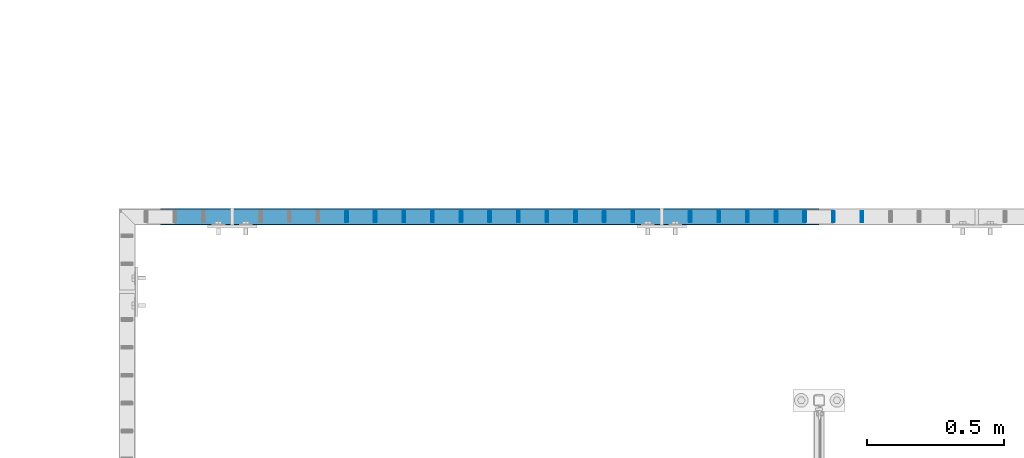
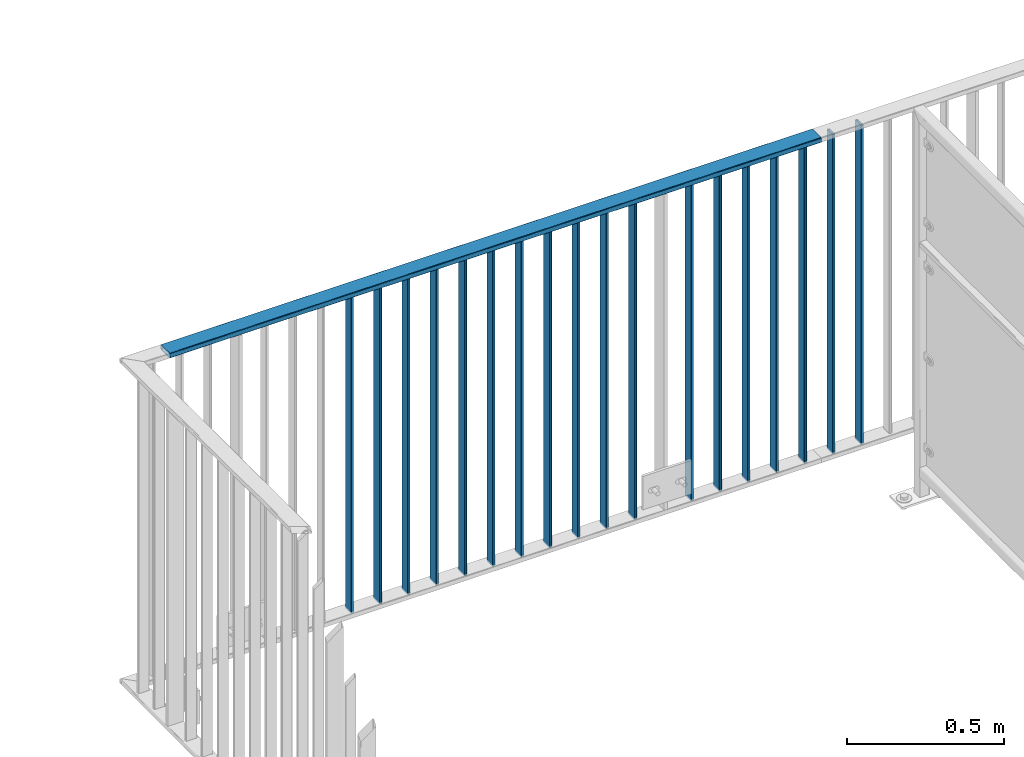
# One storey, part 27 of 156: 19 beams, 2 elements without a shape of their own.
"""IFC2X3 building model written with IfcOpenShell, lengths in millimetres."""

from ifc_helpers import new_model, si_unit, frame, origin_with_axes, origin_2d_with_axis, place, context, subcontext, project, spatial, hollow_rectangle, extrude, clip, halfspace, material, type_object, element, aggregate, save


model = new_model("IFC2X3")

# Units and contexts
model_context = context("Model", 3, precision=1e-05, world=origin_with_axes())
body_context = subcontext(model_context, "Body", "Model", "MODEL_VIEW")
ifc_project = project(units=[si_unit("LENGTHUNIT", "METRE", prefix="MILLI"), si_unit("AREAUNIT", "SQUARE_METRE"), si_unit("VOLUMEUNIT", "CUBIC_METRE"), si_unit("MASSUNIT", "GRAM", prefix="KILO"), si_unit("TIMEUNIT", "SECOND"), si_unit("PLANEANGLEUNIT", "RADIAN"), si_unit("SOLIDANGLEUNIT", "STERADIAN"), si_unit("THERMODYNAMICTEMPERATUREUNIT", "DEGREE_CELSIUS"), si_unit("LUMINOUSINTENSITYUNIT", "LUMEN")], contexts=[model_context])

# Site, building, storey
site_placement = place(None, origin_with_axes())
site = spatial("IfcSite", under=ifc_project, at=site_placement, CompositionType="ELEMENT")
building_placement = place(site_placement, origin_with_axes())
building = spatial("IfcBuilding", under=site, at=building_placement, Name="Undefined", CompositionType="ELEMENT")
storey_placement = place(building_placement, origin_with_axes())
storey = spatial("IfcBuildingStorey", under=building, at=storey_placement, Name="Undefined", CompositionType="ELEMENT", Elevation=0.0)

# Assembly, beams
assembly_1_placement = place(storey_placement, origin_with_axes())
assembly_1 = element("IfcElementAssembly", 1, at=assembly_1_placement, inside=storey, AssemblyPlace="NOTDEFINED", PredefinedType="RIGID_FRAME")
ifc_material = material(Name="STEEL/S235JR")
beam_type_1 = type_object("IfcBeamType", Name="K60/20/2", PredefinedType="NOTDEFINED")
beam_1_placement = place(assembly_1_placement, frame((33999.9535961914, 21657.9919947282, 3990.0), z_axis=(0.0, -1.0, 0.0), x_axis=(-1.0, 0.0, 0.0)))
beam_1 = element("IfcBeam", 2, at=beam_1_placement, type_object=beam_type_1, material=ifc_material, ObjectType="K60/20/2", context=body_context, shape_type="SweptSolid", body=[
    extrude(hollow_rectangle(XDim=20.0, YDim=60.0, WallThickness=2.0, InnerFilletRadius=2.0, OuterFilletRadius=4.0, at=origin_2d_with_axis()), frame((2402.81, 0.0, 0.0), z_axis=(-1.0, 0.0, 0.0), x_axis=(0.0, -1.0, 0.0)), (0.0, 0.0, 1.0), 2402.81),
])
beam_type_2 = type_object("IfcBeamType", Name="K40/10/1.5", PredefinedType="NOTDEFINED")
beam_2_placement = place(assembly_1_placement, frame((33320.8985961914, 21657.9919947282, 3980.00000000003), z_axis=(0.0, -1.0, 0.0), x_axis=(0.0, 0.0, -1.0)))
beam_2 = element("IfcBeam", 3, at=beam_2_placement, type_object=beam_type_2, material=ifc_material, ObjectType="K40/10/1.5", context=body_context, shape_type="Clipping", body=[
    clip(clip(extrude(hollow_rectangle(XDim=10.0, YDim=40.0, WallThickness=1.5, InnerFilletRadius=1.5, OuterFilletRadius=3.0, at=origin_2d_with_axis()), frame((1237.00000000003, 0.0, 0.0), z_axis=(-1.0, 0.0, 0.0), x_axis=(0.0, -1.0, 0.0)), (0.0, 0.0, 1.0), 1244.0), halfspace(frame((1237.00000000003, 4.34248751949781, 47.3810900558092), z_axis=(1.0, 0.0, 0.0), x_axis=(0.0, -0.768354814194188, -0.640024124158313)), False)), halfspace(frame((-6.99999999997453, -4.34248751950508, 47.3810900558092), z_axis=(-1.0, 0.0, 0.0), x_axis=(0.0, 0.7683548141934, -0.640024124159258)), False)),
])
beam_3_placement = place(assembly_1_placement, frame((32276.1985961914, 21657.9919947282, 3980.00000000003), z_axis=(0.0, -1.0, 0.0), x_axis=(0.0, 0.0, -1.0)))
beam_3 = element("IfcBeam", 4, at=beam_3_placement, type_object=beam_type_2, material=ifc_material, ObjectType="K40/10/1.5", context=body_context, shape_type="Clipping", body=[
    clip(clip(extrude(hollow_rectangle(XDim=10.0, YDim=40.0, WallThickness=1.5, InnerFilletRadius=1.5, OuterFilletRadius=3.0, at=origin_2d_with_axis()), frame((1237.00000000003, 0.0, 0.0), z_axis=(-1.0, 0.0, 0.0), x_axis=(0.0, -1.0, 0.0)), (0.0, 0.0, 1.0), 1244.0), halfspace(frame((1237.00000000003, 4.34248751949781, 47.3810900558092), z_axis=(1.0, 0.0, 0.0), x_axis=(0.0, -0.768354814194188, -0.640024124158313)), False)), halfspace(frame((-6.99999999997453, -4.34248751950508, 47.3810900558092), z_axis=(-1.0, 0.0, 0.0), x_axis=(0.0, 0.7683548141934, -0.640024124159258)), False)),
])
beam_4_placement = place(assembly_1_placement, frame((32380.6685961914, 21657.9919947282, 3980.00000000003), z_axis=(0.0, -1.0, 0.0), x_axis=(0.0, 0.0, -1.0)))
beam_4 = element("IfcBeam", 5, at=beam_4_placement, type_object=beam_type_2, material=ifc_material, ObjectType="K40/10/1.5", context=body_context, shape_type="Clipping", body=[
    clip(clip(extrude(hollow_rectangle(XDim=10.0, YDim=40.0, WallThickness=1.5, InnerFilletRadius=1.5, OuterFilletRadius=3.0, at=origin_2d_with_axis()), frame((1237.00000000003, 0.0, 0.0), z_axis=(-1.0, 0.0, 0.0), x_axis=(0.0, -1.0, 0.0)), (0.0, 0.0, 1.0), 1244.0), halfspace(frame((1237.00000000003, 4.34248751949781, 47.3810900558092), z_axis=(1.0, 0.0, 0.0), x_axis=(0.0, -0.768354814194188, -0.640024124158313)), False)), halfspace(frame((-6.99999999997453, -4.34248751950508, 47.3810900558092), z_axis=(-1.0, 0.0, 0.0), x_axis=(0.0, 0.7683548141934, -0.640024124159258)), False)),
])
beam_5_placement = place(assembly_1_placement, frame((32485.1385961914, 21657.9919947282, 3980.00000000003), z_axis=(0.0, -1.0, 0.0), x_axis=(0.0, 0.0, -1.0)))
beam_5 = element("IfcBeam", 6, at=beam_5_placement, type_object=beam_type_2, material=ifc_material, ObjectType="K40/10/1.5", context=body_context, shape_type="Clipping", body=[
    clip(clip(extrude(hollow_rectangle(XDim=10.0, YDim=40.0, WallThickness=1.5, InnerFilletRadius=1.5, OuterFilletRadius=3.0, at=origin_2d_with_axis()), frame((1237.00000000003, 0.0, 0.0), z_axis=(-1.0, 0.0, 0.0), x_axis=(0.0, -1.0, 0.0)), (0.0, 0.0, 1.0), 1244.0), halfspace(frame((1237.00000000003, 4.34248751949781, 47.3810900558092), z_axis=(1.0, 0.0, 0.0), x_axis=(0.0, -0.768354814194188, -0.640024124158313)), False)), halfspace(frame((-6.99999999997453, -4.34248751950508, 47.3810900558092), z_axis=(-1.0, 0.0, 0.0), x_axis=(0.0, 0.7683548141934, -0.640024124159258)), False)),
])
beam_6_placement = place(assembly_1_placement, frame((32589.6085961914, 21657.9919947282, 3980.00000000003), z_axis=(0.0, -1.0, 0.0), x_axis=(0.0, 0.0, -1.0)))
beam_6 = element("IfcBeam", 7, at=beam_6_placement, type_object=beam_type_2, material=ifc_material, ObjectType="K40/10/1.5", context=body_context, shape_type="Clipping", body=[
    clip(clip(extrude(hollow_rectangle(XDim=10.0, YDim=40.0, WallThickness=1.5, InnerFilletRadius=1.5, OuterFilletRadius=3.0, at=origin_2d_with_axis()), frame((1237.00000000003, 0.0, 0.0), z_axis=(-1.0, 0.0, 0.0), x_axis=(0.0, -1.0, 0.0)), (0.0, 0.0, 1.0), 1244.0), halfspace(frame((1237.00000000003, 4.34248751949781, 47.3810900558092), z_axis=(1.0, 0.0, 0.0), x_axis=(0.0, -0.768354814194188, -0.640024124158313)), False)), halfspace(frame((-6.99999999997453, -4.34248751950508, 47.3810900558092), z_axis=(-1.0, 0.0, 0.0), x_axis=(0.0, 0.7683548141934, -0.640024124159258)), False)),
])
beam_7_placement = place(assembly_1_placement, frame((32694.0785961914, 21657.9919947282, 3980.00000000003), z_axis=(0.0, -1.0, 0.0), x_axis=(0.0, 0.0, -1.0)))
beam_7 = element("IfcBeam", 8, at=beam_7_placement, type_object=beam_type_2, material=ifc_material, ObjectType="K40/10/1.5", context=body_context, shape_type="Clipping", body=[
    clip(clip(extrude(hollow_rectangle(XDim=10.0, YDim=40.0, WallThickness=1.5, InnerFilletRadius=1.5, OuterFilletRadius=3.0, at=origin_2d_with_axis()), frame((1237.00000000003, 0.0, 0.0), z_axis=(-1.0, 0.0, 0.0), x_axis=(0.0, -1.0, 0.0)), (0.0, 0.0, 1.0), 1244.0), halfspace(frame((1237.00000000003, 4.34248751949781, 47.3810900558092), z_axis=(1.0, 0.0, 0.0), x_axis=(0.0, -0.768354814194188, -0.640024124158313)), False)), halfspace(frame((-6.99999999997453, -4.34248751950508, 47.3810900558092), z_axis=(-1.0, 0.0, 0.0), x_axis=(0.0, 0.7683548141934, -0.640024124159258)), False)),
])
beam_8_placement = place(assembly_1_placement, frame((32798.5485961914, 21657.9919947282, 3980.00000000003), z_axis=(0.0, -1.0, 0.0), x_axis=(0.0, 0.0, -1.0)))
beam_8 = element("IfcBeam", 9, at=beam_8_placement, type_object=beam_type_2, material=ifc_material, ObjectType="K40/10/1.5", context=body_context, shape_type="Clipping", body=[
    clip(clip(extrude(hollow_rectangle(XDim=10.0, YDim=40.0, WallThickness=1.5, InnerFilletRadius=1.5, OuterFilletRadius=3.0, at=origin_2d_with_axis()), frame((1237.00000000003, 0.0, 0.0), z_axis=(-1.0, 0.0, 0.0), x_axis=(0.0, -1.0, 0.0)), (0.0, 0.0, 1.0), 1244.0), halfspace(frame((1237.00000000003, 4.34248751949781, 47.3810900558092), z_axis=(1.0, 0.0, 0.0), x_axis=(0.0, -0.768354814194188, -0.640024124158313)), False)), halfspace(frame((-6.99999999997453, -4.34248751950508, 47.3810900558092), z_axis=(-1.0, 0.0, 0.0), x_axis=(0.0, 0.7683548141934, -0.640024124159258)), False)),
])
beam_9_placement = place(assembly_1_placement, frame((32903.0185961914, 21657.9919947282, 3980.00000000003), z_axis=(0.0, -1.0, 0.0), x_axis=(0.0, 0.0, -1.0)))
beam_9 = element("IfcBeam", 10, at=beam_9_placement, type_object=beam_type_2, material=ifc_material, ObjectType="K40/10/1.5", context=body_context, shape_type="Clipping", body=[
    clip(clip(extrude(hollow_rectangle(XDim=10.0, YDim=40.0, WallThickness=1.5, InnerFilletRadius=1.5, OuterFilletRadius=3.0, at=origin_2d_with_axis()), frame((1237.00000000003, 0.0, 0.0), z_axis=(-1.0, 0.0, 0.0), x_axis=(0.0, -1.0, 0.0)), (0.0, 0.0, 1.0), 1244.0), halfspace(frame((1237.00000000003, 4.34248751949781, 47.3810900558092), z_axis=(1.0, 0.0, 0.0), x_axis=(0.0, -0.768354814194188, -0.640024124158313)), False)), halfspace(frame((-6.99999999997453, -4.34248751950508, 47.3810900558092), z_axis=(-1.0, 0.0, 0.0), x_axis=(0.0, 0.7683548141934, -0.640024124159258)), False)),
])
beam_10_placement = place(assembly_1_placement, frame((33007.4885961914, 21657.9919947282, 3980.00000000003), z_axis=(0.0, -1.0, 0.0), x_axis=(0.0, 0.0, -1.0)))
beam_10 = element("IfcBeam", 11, at=beam_10_placement, type_object=beam_type_2, material=ifc_material, ObjectType="K40/10/1.5", context=body_context, shape_type="Clipping", body=[
    clip(clip(extrude(hollow_rectangle(XDim=10.0, YDim=40.0, WallThickness=1.5, InnerFilletRadius=1.5, OuterFilletRadius=3.0, at=origin_2d_with_axis()), frame((1237.00000000003, 0.0, 0.0), z_axis=(-1.0, 0.0, 0.0), x_axis=(0.0, -1.0, 0.0)), (0.0, 0.0, 1.0), 1244.0), halfspace(frame((1237.00000000003, 4.34248751949781, 47.3810900558092), z_axis=(1.0, 0.0, 0.0), x_axis=(0.0, -0.768354814194188, -0.640024124158313)), False)), halfspace(frame((-6.99999999997453, -4.34248751950508, 47.3810900558092), z_axis=(-1.0, 0.0, 0.0), x_axis=(0.0, 0.7683548141934, -0.640024124159258)), False)),
])
beam_11_placement = place(assembly_1_placement, frame((33111.9585961914, 21657.9919947282, 3980.00000000003), z_axis=(0.0, -1.0, 0.0), x_axis=(0.0, 0.0, -1.0)))
beam_11 = element("IfcBeam", 12, at=beam_11_placement, type_object=beam_type_2, material=ifc_material, ObjectType="K40/10/1.5", context=body_context, shape_type="Clipping", body=[
    clip(clip(extrude(hollow_rectangle(XDim=10.0, YDim=40.0, WallThickness=1.5, InnerFilletRadius=1.5, OuterFilletRadius=3.0, at=origin_2d_with_axis()), frame((1237.00000000003, 0.0, 0.0), z_axis=(-1.0, 0.0, 0.0), x_axis=(0.0, -1.0, 0.0)), (0.0, 0.0, 1.0), 1244.0), halfspace(frame((1237.00000000003, 4.34248751949781, 47.3810900558092), z_axis=(1.0, 0.0, 0.0), x_axis=(0.0, -0.768354814194188, -0.640024124158313)), False)), halfspace(frame((-6.99999999997453, -4.34248751950508, 47.3810900558092), z_axis=(-1.0, 0.0, 0.0), x_axis=(0.0, 0.7683548141934, -0.640024124159258)), False)),
])
beam_12_placement = place(assembly_1_placement, frame((33216.4285961914, 21657.9919947282, 3980.00000000003), z_axis=(0.0, -1.0, 0.0), x_axis=(0.0, 0.0, -1.0)))
beam_12 = element("IfcBeam", 13, at=beam_12_placement, type_object=beam_type_2, material=ifc_material, ObjectType="K40/10/1.5", context=body_context, shape_type="Clipping", body=[
    clip(clip(extrude(hollow_rectangle(XDim=10.0, YDim=40.0, WallThickness=1.5, InnerFilletRadius=1.5, OuterFilletRadius=3.0, at=origin_2d_with_axis()), frame((1237.00000000003, 0.0, 0.0), z_axis=(-1.0, 0.0, 0.0), x_axis=(0.0, -1.0, 0.0)), (0.0, 0.0, 1.0), 1244.0), halfspace(frame((1237.00000000003, 4.34248751949781, 47.3810900558092), z_axis=(1.0, 0.0, 0.0), x_axis=(0.0, -0.768354814194188, -0.640024124158313)), False)), halfspace(frame((-6.99999999997453, -4.34248751950508, 47.3810900558092), z_axis=(-1.0, 0.0, 0.0), x_axis=(0.0, 0.7683548141934, -0.640024124159258)), False)),
])
beam_13_placement = place(assembly_1_placement, frame((33529.8385961914, 21657.9919947282, 3980.00000000003), z_axis=(0.0, -1.0, 0.0), x_axis=(0.0, 0.0, -1.0)))
beam_13 = element("IfcBeam", 14, at=beam_13_placement, type_object=beam_type_2, material=ifc_material, ObjectType="K40/10/1.5", context=body_context, shape_type="Clipping", body=[
    clip(clip(extrude(hollow_rectangle(XDim=10.0, YDim=40.0, WallThickness=1.5, InnerFilletRadius=1.5, OuterFilletRadius=3.0, at=origin_2d_with_axis()), frame((1237.00000000003, 0.0, 0.0), z_axis=(-1.0, 0.0, 0.0), x_axis=(0.0, -1.0, 0.0)), (0.0, 0.0, 1.0), 1244.0), halfspace(frame((1237.00000000003, 4.34248751949781, 47.3810900558092), z_axis=(1.0, 0.0, 0.0), x_axis=(0.0, -0.768354814194188, -0.640024124158313)), False)), halfspace(frame((-6.99999999997453, -4.34248751950508, 47.3810900558092), z_axis=(-1.0, 0.0, 0.0), x_axis=(0.0, 0.7683548141934, -0.640024124159258)), False)),
])
beam_14_placement = place(assembly_1_placement, frame((33634.3085961914, 21657.9919947282, 3980.00000000003), z_axis=(0.0, -1.0, 0.0), x_axis=(0.0, 0.0, -1.0)))
beam_14 = element("IfcBeam", 15, at=beam_14_placement, type_object=beam_type_2, material=ifc_material, ObjectType="K40/10/1.5", context=body_context, shape_type="Clipping", body=[
    clip(clip(extrude(hollow_rectangle(XDim=10.0, YDim=40.0, WallThickness=1.5, InnerFilletRadius=1.5, OuterFilletRadius=3.0, at=origin_2d_with_axis()), frame((1237.00000000003, 0.0, 0.0), z_axis=(-1.0, 0.0, 0.0), x_axis=(0.0, -1.0, 0.0)), (0.0, 0.0, 1.0), 1244.0), halfspace(frame((1237.00000000003, 4.34248751949781, 47.3810900558092), z_axis=(1.0, 0.0, 0.0), x_axis=(0.0, -0.768354814194188, -0.640024124158313)), False)), halfspace(frame((-6.99999999997453, -4.34248751950508, 47.3810900558092), z_axis=(-1.0, 0.0, 0.0), x_axis=(0.0, 0.7683548141934, -0.640024124159258)), False)),
])
beam_15_placement = place(assembly_1_placement, frame((33738.7785961914, 21657.9919947282, 3980.00000000003), z_axis=(0.0, -1.0, 0.0), x_axis=(0.0, 0.0, -1.0)))
beam_15 = element("IfcBeam", 16, at=beam_15_placement, type_object=beam_type_2, material=ifc_material, ObjectType="K40/10/1.5", context=body_context, shape_type="Clipping", body=[
    clip(clip(extrude(hollow_rectangle(XDim=10.0, YDim=40.0, WallThickness=1.5, InnerFilletRadius=1.5, OuterFilletRadius=3.0, at=origin_2d_with_axis()), frame((1237.00000000003, 0.0, 0.0), z_axis=(-1.0, 0.0, 0.0), x_axis=(0.0, -1.0, 0.0)), (0.0, 0.0, 1.0), 1244.0), halfspace(frame((1237.00000000003, 4.34248751949781, 47.3810900558092), z_axis=(1.0, 0.0, 0.0), x_axis=(0.0, -0.768354814194188, -0.640024124158313)), False)), halfspace(frame((-6.99999999997453, -4.34248751950508, 47.3810900558092), z_axis=(-1.0, 0.0, 0.0), x_axis=(0.0, 0.7683548141934, -0.640024124159258)), False)),
])
beam_16_placement = place(assembly_1_placement, frame((33843.2485961914, 21657.9919947282, 3980.00000000003), z_axis=(0.0, -1.0, 0.0), x_axis=(0.0, 0.0, -1.0)))
beam_16 = element("IfcBeam", 17, at=beam_16_placement, type_object=beam_type_2, material=ifc_material, ObjectType="K40/10/1.5", context=body_context, shape_type="Clipping", body=[
    clip(clip(extrude(hollow_rectangle(XDim=10.0, YDim=40.0, WallThickness=1.5, InnerFilletRadius=1.5, OuterFilletRadius=3.0, at=origin_2d_with_axis()), frame((1237.00000000003, 0.0, 0.0), z_axis=(-1.0, 0.0, 0.0), x_axis=(0.0, -1.0, 0.0)), (0.0, 0.0, 1.0), 1244.0), halfspace(frame((1237.00000000003, 4.34248751949781, 47.3810900558092), z_axis=(1.0, 0.0, 0.0), x_axis=(0.0, -0.768354814194188, -0.640024124158313)), False)), halfspace(frame((-6.99999999997453, -4.34248751950508, 47.3810900558092), z_axis=(-1.0, 0.0, 0.0), x_axis=(0.0, 0.7683548141934, -0.640024124159258)), False)),
])
beam_17_placement = place(assembly_1_placement, frame((33947.7185961914, 21657.9919947282, 3980.00000000003), z_axis=(0.0, -1.0, 0.0), x_axis=(0.0, 0.0, -1.0)))
beam_17 = element("IfcBeam", 18, at=beam_17_placement, type_object=beam_type_2, material=ifc_material, ObjectType="K40/10/1.5", context=body_context, shape_type="Clipping", body=[
    clip(clip(extrude(hollow_rectangle(XDim=10.0, YDim=40.0, WallThickness=1.5, InnerFilletRadius=1.5, OuterFilletRadius=3.0, at=origin_2d_with_axis()), frame((1237.00000000003, 0.0, 0.0), z_axis=(-1.0, 0.0, 0.0), x_axis=(0.0, -1.0, 0.0)), (0.0, 0.0, 1.0), 1244.0), halfspace(frame((1237.00000000003, 4.34248751949781, 47.3810900558092), z_axis=(1.0, 0.0, 0.0), x_axis=(0.0, -0.768354814194188, -0.640024124158313)), False)), halfspace(frame((-6.99999999997453, -4.34248751950508, 47.3810900558092), z_axis=(-1.0, 0.0, 0.0), x_axis=(0.0, 0.7683548141934, -0.640024124159258)), False)),
])
aggregate(assembly_1, [beam_2, beam_3, beam_4, beam_5, beam_6, beam_7, beam_8, beam_9, beam_10, beam_11, beam_12, beam_13, beam_14, beam_15, beam_16, beam_17, beam_1])

assembly_2_placement = place(storey_placement, origin_with_axes())
assembly_2 = element("IfcElementAssembly", 19, at=assembly_2_placement, inside=storey, AssemblyPlace="NOTDEFINED", PredefinedType="RIGID_FRAME")
beam_18_placement = place(assembly_2_placement, frame((34052.1885961914, 21657.9919947282, 3980.00000000003), z_axis=(0.0, -1.0, 0.0), x_axis=(0.0, 0.0, -1.0)))
beam_18 = element("IfcBeam", 20, at=beam_18_placement, type_object=beam_type_2, material=ifc_material, ObjectType="K40/10/1.5", context=body_context, shape_type="Clipping", body=[
    clip(clip(extrude(hollow_rectangle(XDim=10.0, YDim=40.0, WallThickness=1.5, InnerFilletRadius=1.5, OuterFilletRadius=3.0, at=origin_2d_with_axis()), frame((1237.00000000003, 0.0, 0.0), z_axis=(-1.0, 0.0, 0.0), x_axis=(0.0, -1.0, 0.0)), (0.0, 0.0, 1.0), 1244.0), halfspace(frame((1237.00000000003, 4.34248751949781, 47.3810900558092), z_axis=(1.0, 0.0, 0.0), x_axis=(0.0, -0.768354814194188, -0.640024124158313)), False)), halfspace(frame((-6.99999999997453, -4.34248751950508, 47.3810900558092), z_axis=(-1.0, 0.0, 0.0), x_axis=(0.0, 0.7683548141934, -0.640024124159258)), False)),
])
beam_19_placement = place(assembly_2_placement, frame((34156.6585961914, 21657.9919947282, 3980.00000000003), z_axis=(0.0, -1.0, 0.0), x_axis=(0.0, 0.0, -1.0)))
beam_19 = element("IfcBeam", 21, at=beam_19_placement, type_object=beam_type_2, material=ifc_material, ObjectType="K40/10/1.5", context=body_context, shape_type="Clipping", body=[
    clip(clip(extrude(hollow_rectangle(XDim=10.0, YDim=40.0, WallThickness=1.5, InnerFilletRadius=1.5, OuterFilletRadius=3.0, at=origin_2d_with_axis()), frame((1237.00000000003, 0.0, 0.0), z_axis=(-1.0, 0.0, 0.0), x_axis=(0.0, -1.0, 0.0)), (0.0, 0.0, 1.0), 1244.0), halfspace(frame((1237.00000000003, 4.34248751949781, 47.3810900558092), z_axis=(1.0, 0.0, 0.0), x_axis=(0.0, -0.768354814194188, -0.640024124158313)), False)), halfspace(frame((-6.99999999997453, -4.34248751950508, 47.3810900558092), z_axis=(-1.0, 0.0, 0.0), x_axis=(0.0, 0.7683548141934, -0.640024124159258)), False)),
])
aggregate(assembly_2, [beam_18, beam_19])

save(model, "model.ifc")
